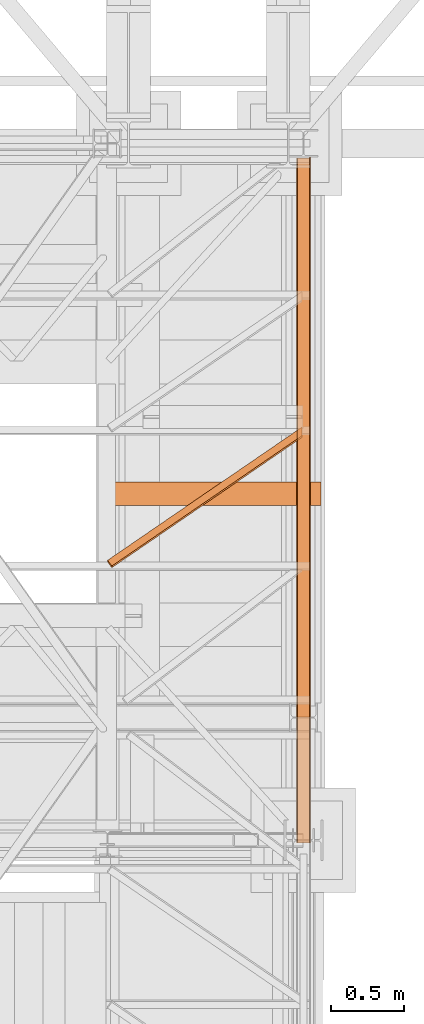
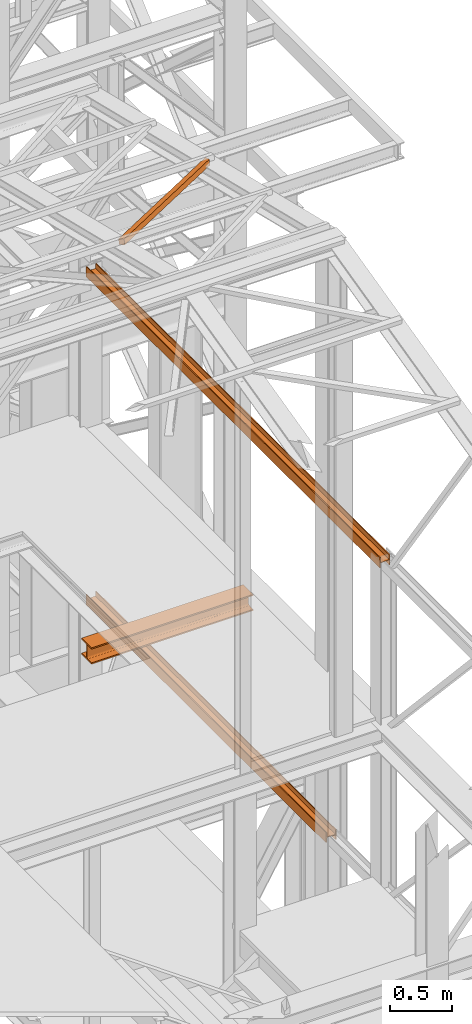
# One storey, part 66 of 208: 5 proxies.
"""IFC2X3 building model written with IfcOpenShell, lengths in millimetres."""

from ifc_helpers import new_model, entity, si_unit, converted_unit, frame, origin, origin_with_axes, place, context, subcontext, project, spatial, faceted_brep, element, save


model = new_model("IFC2X3")

# Units and contexts
model_context = context("Model", 3, precision=1e-05, world=origin())
plan_context = context("Plan", 3, precision=1e-05, world=origin())
body_context = subcontext(model_context, "Body", "Model", "MODEL_VIEW")
ifc_project = project(units=[si_unit("LENGTHUNIT", "METRE", prefix="MILLI"), converted_unit("PLANEANGLEUNIT", "DEGREE", entity("IfcPlaneAngleMeasure", 0.0174532925199433), si_unit("PLANEANGLEUNIT", "RADIAN"), dimensions=[0, 0, 0, 0, 0, 0, 0]), si_unit("AREAUNIT", "SQUARE_METRE"), si_unit("VOLUMEUNIT", "CUBIC_METRE")], contexts=[model_context, plan_context])

# Building, storey
building_placement = place(None, origin())
building = spatial("IfcBuilding", under=ifc_project, at=building_placement, CompositionType="COMPLEX")
storey_placement = place(building_placement, origin_with_axes())
storey = spatial("IfcBuildingStorey", under=building, at=storey_placement, Name="Geschoss", CompositionType="ELEMENT")

# Proxies
proxy_1_placement = place(storey_placement, frame((6650.254968528656, -22080.57439140567, 9977.24968077644), z_axis=(0.0, 0.0, 1.0), x_axis=(1.0, 0.0, 0.0)))
element("IfcBuildingElementProxy", 1, at=proxy_1_placement, inside=storey, context=body_context, shape_type="Brep", body=[
    faceted_brep([(8.010000000000218, 0.01000000000203727, 2.75031996861253), (0.01000000000021828, 0.01000000000203727, 2.75031996861253), (0.01000000000021828, 0.01000000000203727, 102.7503199686125), (8.010000000000218, 0.01000000000203727, 102.7503199686125), (8.010000000000218, 0.01000000000203727, 55.25031996861253), (88.01000000000022, 0.01000000000203727, 55.25031996861253), (88.01000000000022, 0.01000000000203727, 102.7503199686125), (96.01000000000022, 0.01000000000203727, 102.7503199686125), (96.01000000000022, 0.01000000000203727, 2.75031996861253), (88.01000000000022, 0.01000000000203727, 2.75031996861253), (88.01000000000022, 0.01000000000203727, 50.25031996861253), (8.010000000000218, 0.01000000000203727, 50.25031996861253), (0.01000000000021828, 0.01000000000203727, 2.75031996861253), (8.010000000000218, 0.01000000000203727, 2.75031996861253), (8.010000000001128, 4718.009999597674, 0.00999999999839929), (0.01000000000112777, 4718.009999597674, 0.00999999999839929), (0.01000000000021828, 0.01000000000203727, 102.7503199686125), (0.01000000000021828, 0.01000000000203727, 2.75031996861253), (0.01000000000112777, 4718.009999597674, 0.00999999999839929), (0.01000000000112777, 4718.009999597674, 100.0099999999984), (8.010000000000218, 0.01000000000203727, 102.7503199686125), (0.01000000000021828, 0.01000000000203727, 102.7503199686125), (0.01000000000112777, 4718.009999597674, 100.0099999999984), (8.010000000001128, 4718.009999597674, 100.0099999999984), (8.010000000000218, 0.01000000000203727, 55.25031996861253), (8.010000000000218, 0.01000000000203727, 102.7503199686125), (8.010000000001128, 4718.009999597674, 100.0099999999984), (8.010000000001128, 4718.009999597674, 52.5099999999984), (88.01000000000022, 0.01000000000203727, 55.25031996861253), (8.010000000000218, 0.01000000000203727, 55.25031996861253), (8.010000000001128, 4718.009999597674, 52.5099999999984), (88.01000000000113, 4718.009999597674, 52.5099999999984), (88.01000000000022, 0.01000000000203727, 102.7503199686125), (88.01000000000022, 0.01000000000203727, 55.25031996861253), (88.01000000000113, 4718.009999597674, 52.5099999999984), (88.01000000000113, 4718.009999597674, 100.0099999999984), (96.01000000000022, 0.01000000000203727, 102.7503199686125), (88.01000000000022, 0.01000000000203727, 102.7503199686125), (88.01000000000113, 4718.009999597674, 100.0099999999984), (96.01000000000113, 4718.009999597674, 100.0099999999984), (96.01000000000022, 0.01000000000203727, 2.75031996861253), (96.01000000000022, 0.01000000000203727, 102.7503199686125), (96.01000000000113, 4718.009999597674, 100.0099999999984), (96.01000000000113, 4718.009999597674, 0.00999999999839929), (88.01000000000022, 0.01000000000203727, 2.75031996861253), (96.01000000000022, 0.01000000000203727, 2.75031996861253), (96.01000000000113, 4718.009999597674, 0.00999999999839929), (88.01000000000113, 4718.009999597674, 0.00999999999839929), (88.01000000000022, 0.01000000000203727, 50.25031996861253), (88.01000000000022, 0.01000000000203727, 2.75031996861253), (88.01000000000113, 4718.009999597674, 0.00999999999839929), (88.01000000000113, 4718.009999597674, 47.5099999999984), (8.010000000000218, 0.01000000000203727, 50.25031996861253), (88.01000000000022, 0.01000000000203727, 50.25031996861253), (88.01000000000113, 4718.009999597674, 47.5099999999984), (8.010000000001128, 4718.009999597674, 47.5099999999984), (8.010000000000218, 0.01000000000203727, 2.75031996861253), (8.010000000000218, 0.01000000000203727, 50.25031996861253), (8.010000000001128, 4718.009999597674, 47.5099999999984), (8.010000000001128, 4718.009999597674, 0.00999999999839929), (8.010000000001128, 4718.009999597674, 0.00999999999839929), (8.010000000001128, 4718.009999597674, 47.5099999999984), (88.01000000000113, 4718.009999597674, 47.5099999999984), (88.01000000000113, 4718.009999597674, 0.00999999999839929), (96.01000000000113, 4718.009999597674, 0.00999999999839929), (96.01000000000113, 4718.009999597674, 100.0099999999984), (88.01000000000113, 4718.009999597674, 100.0099999999984), (88.01000000000113, 4718.009999597674, 52.5099999999984), (8.010000000001128, 4718.009999597674, 52.5099999999984), (8.010000000001128, 4718.009999597674, 100.0099999999984), (0.01000000000112777, 4718.009999597674, 100.0099999999984), (0.01000000000112777, 4718.009999597674, 0.00999999999839929)], [[[0, 1, 2, 3, 4, 5, 6, 7, 8, 9, 10, 11]], [[12, 13, 14, 15]], [[16, 17, 18, 19]], [[20, 21, 22, 23]], [[24, 25, 26, 27]], [[28, 29, 30, 31]], [[32, 33, 34, 35]], [[36, 37, 38, 39]], [[40, 41, 42, 43]], [[44, 45, 46, 47]], [[48, 49, 50, 51]], [[52, 53, 54, 55]], [[56, 57, 58, 59]], [[60, 61, 62, 63, 64, 65, 66, 67, 68, 69, 70, 71]]], orient=[[False], [False], [False], [False], [False], [False], [False], [False], [False], [False], [False], [False], [False], [False]]),
])
proxy_2_placement = place(storey_placement, frame((6650.254968528656, -22080.57439140567, 9977.24968077644), z_axis=(0.0, 0.0, 1.0), x_axis=(1.0, 0.0, 0.0)))
element("IfcBuildingElementProxy", 2, at=proxy_2_placement, inside=storey, context=body_context, shape_type="Brep", body=[
    faceted_brep([(8.010000000000218, 0.01000000000203727, 2.75031996861253), (0.01000000000021828, 0.01000000000203727, 2.75031996861253), (0.01000000000021828, 0.01000000000203727, 102.7503199686125), (8.010000000000218, 0.01000000000203727, 102.7503199686125), (8.010000000000218, 0.01000000000203727, 55.25031996861253), (88.01000000000022, 0.01000000000203727, 55.25031996861253), (88.01000000000022, 0.01000000000203727, 102.7503199686125), (96.01000000000022, 0.01000000000203727, 102.7503199686125), (96.01000000000022, 0.01000000000203727, 2.75031996861253), (88.01000000000022, 0.01000000000203727, 2.75031996861253), (88.01000000000022, 0.01000000000203727, 50.25031996861253), (8.010000000000218, 0.01000000000203727, 50.25031996861253), (0.01000000000021828, 0.01000000000203727, 2.75031996861253), (8.010000000000218, 0.01000000000203727, 2.75031996861253), (8.010000000001128, 4718.009999597674, 0.00999999999839929), (0.01000000000112777, 4718.009999597674, 0.00999999999839929), (0.01000000000021828, 0.01000000000203727, 102.7503199686125), (0.01000000000021828, 0.01000000000203727, 2.75031996861253), (0.01000000000112777, 4718.009999597674, 0.00999999999839929), (0.01000000000112777, 4718.009999597674, 100.0099999999984), (8.010000000000218, 0.01000000000203727, 102.7503199686125), (0.01000000000021828, 0.01000000000203727, 102.7503199686125), (0.01000000000112777, 4718.009999597674, 100.0099999999984), (8.010000000001128, 4718.009999597674, 100.0099999999984), (8.010000000000218, 0.01000000000203727, 55.25031996861253), (8.010000000000218, 0.01000000000203727, 102.7503199686125), (8.010000000001128, 4718.009999597674, 100.0099999999984), (8.010000000001128, 4718.009999597674, 52.5099999999984), (88.01000000000022, 0.01000000000203727, 55.25031996861253), (8.010000000000218, 0.01000000000203727, 55.25031996861253), (8.010000000001128, 4718.009999597674, 52.5099999999984), (88.01000000000113, 4718.009999597674, 52.5099999999984), (88.01000000000022, 0.01000000000203727, 102.7503199686125), (88.01000000000022, 0.01000000000203727, 55.25031996861253), (88.01000000000113, 4718.009999597674, 52.5099999999984), (88.01000000000113, 4718.009999597674, 100.0099999999984), (96.01000000000022, 0.01000000000203727, 102.7503199686125), (88.01000000000022, 0.01000000000203727, 102.7503199686125), (88.01000000000113, 4718.009999597674, 100.0099999999984), (96.01000000000113, 4718.009999597674, 100.0099999999984), (96.01000000000022, 0.01000000000203727, 2.75031996861253), (96.01000000000022, 0.01000000000203727, 102.7503199686125), (96.01000000000113, 4718.009999597674, 100.0099999999984), (96.01000000000113, 4718.009999597674, 0.00999999999839929), (88.01000000000022, 0.01000000000203727, 2.75031996861253), (96.01000000000022, 0.01000000000203727, 2.75031996861253), (96.01000000000113, 4718.009999597674, 0.00999999999839929), (88.01000000000113, 4718.009999597674, 0.00999999999839929), (88.01000000000022, 0.01000000000203727, 50.25031996861253), (88.01000000000022, 0.01000000000203727, 2.75031996861253), (88.01000000000113, 4718.009999597674, 0.00999999999839929), (88.01000000000113, 4718.009999597674, 47.5099999999984), (8.010000000000218, 0.01000000000203727, 50.25031996861253), (88.01000000000022, 0.01000000000203727, 50.25031996861253), (88.01000000000113, 4718.009999597674, 47.5099999999984), (8.010000000001128, 4718.009999597674, 47.5099999999984), (8.010000000000218, 0.01000000000203727, 2.75031996861253), (8.010000000000218, 0.01000000000203727, 50.25031996861253), (8.010000000001128, 4718.009999597674, 47.5099999999984), (8.010000000001128, 4718.009999597674, 0.00999999999839929), (8.010000000001128, 4718.009999597674, 0.00999999999839929), (8.010000000001128, 4718.009999597674, 47.5099999999984), (88.01000000000113, 4718.009999597674, 47.5099999999984), (88.01000000000113, 4718.009999597674, 0.00999999999839929), (96.01000000000113, 4718.009999597674, 0.00999999999839929), (96.01000000000113, 4718.009999597674, 100.0099999999984), (88.01000000000113, 4718.009999597674, 100.0099999999984), (88.01000000000113, 4718.009999597674, 52.5099999999984), (8.010000000001128, 4718.009999597674, 52.5099999999984), (8.010000000001128, 4718.009999597674, 100.0099999999984), (0.01000000000112777, 4718.009999597674, 100.0099999999984), (0.01000000000112777, 4718.009999597674, 0.00999999999839929)], [[[0, 1, 2, 3, 4, 5, 6, 7, 8, 9, 10, 11]], [[12, 13, 14, 15]], [[16, 17, 18, 19]], [[20, 21, 22, 23]], [[24, 25, 26, 27]], [[28, 29, 30, 31]], [[32, 33, 34, 35]], [[36, 37, 38, 39]], [[40, 41, 42, 43]], [[44, 45, 46, 47]], [[48, 49, 50, 51]], [[52, 53, 54, 55]], [[56, 57, 58, 59]], [[60, 61, 62, 63, 64, 65, 66, 67, 68, 69, 70, 71]]], orient=[[False], [False], [False], [False], [False], [False], [False], [False], [False], [False], [False], [False], [False], [False]]),
])
proxy_3_placement = place(storey_placement, frame((6650.25496814422, -21214.32439025083, 6759.989999254943), z_axis=(0.0, 0.0, 1.0), x_axis=(1.0, 0.0, 0.0)))
element("IfcBuildingElementProxy", 3, at=proxy_3_placement, inside=storey, context=body_context, shape_type="Brep", body=[
    faceted_brep([(8.010000000000218, 0.00999999999839929, 0.01000000000021828), (0.01000000000021828, 0.00999999999839929, 0.01000000000021828), (0.01000000000021828, 0.00999999999839929, 100.0100000000002), (8.010000000000218, 0.00999999999839929, 100.0100000000002), (8.010000000000218, 0.00999999999839929, 52.51000000000022), (88.01000000000022, 0.00999999999839929, 52.51000000000022), (88.01000000000022, 0.00999999999839929, 100.0100000000002), (96.00999999999931, 0.00999999999839929, 100.0100000000002), (96.00999999999931, 0.00999999999839929, 0.01000000000021828), (88.01000000000022, 0.00999999999839929, 0.01000000000021828), (88.01000000000022, 0.00999999999839929, 47.51000000000022), (8.010000000000218, 0.00999999999839929, 47.51000000000022), (0.01000000000021828, 0.00999999999839929, 0.01000000000021828), (8.010000000000218, 0.00999999999839929, 0.01000000000021828), (8.010000000000218, 3856.759984999411, 0.01000000000021828), (0.01000000000021828, 3856.759984999411, 0.01000000000021828), (0.01000000000021828, 0.00999999999839929, 100.0100000000002), (0.01000000000021828, 0.00999999999839929, 0.01000000000021828), (0.01000000000021828, 3856.759984999411, 0.01000000000021828), (0.01000000000021828, 3856.759984999411, 100.0100000000002), (8.010000000000218, 0.00999999999839929, 100.0100000000002), (0.01000000000021828, 0.00999999999839929, 100.0100000000002), (0.01000000000021828, 3856.759984999411, 100.0100000000002), (8.010000000000218, 3856.759984999411, 100.0100000000002), (8.010000000000218, 0.00999999999839929, 52.51000000000022), (8.010000000000218, 0.00999999999839929, 100.0100000000002), (8.010000000000218, 3856.759984999411, 100.0100000000002), (8.010000000000218, 3856.759984999411, 52.51000000000022), (88.01000000000022, 0.00999999999839929, 52.51000000000022), (8.010000000000218, 0.00999999999839929, 52.51000000000022), (8.010000000000218, 3856.759984999411, 52.51000000000022), (88.01000000000022, 3856.759984999411, 52.51000000000022), (88.01000000000022, 0.00999999999839929, 100.0100000000002), (88.01000000000022, 0.00999999999839929, 52.51000000000022), (88.01000000000022, 3856.759984999411, 52.51000000000022), (88.01000000000022, 3856.759984999411, 100.0100000000002), (96.00999999999931, 0.00999999999839929, 100.0100000000002), (88.01000000000022, 0.00999999999839929, 100.0100000000002), (88.01000000000022, 3856.759984999411, 100.0100000000002), (96.01000000000022, 3856.759984999411, 100.0100000000002), (96.00999999999931, 0.00999999999839929, 0.01000000000021828), (96.00999999999931, 0.00999999999839929, 100.0100000000002), (96.01000000000022, 3856.759984999411, 100.0100000000002), (96.01000000000022, 3856.759984999411, 0.01000000000021828), (88.01000000000022, 0.00999999999839929, 0.01000000000021828), (96.00999999999931, 0.00999999999839929, 0.01000000000021828), (96.01000000000022, 3856.759984999411, 0.01000000000021828), (88.01000000000022, 3856.759984999411, 0.01000000000021828), (88.01000000000022, 0.00999999999839929, 47.51000000000022), (88.01000000000022, 0.00999999999839929, 0.01000000000021828), (88.01000000000022, 3856.759984999411, 0.01000000000021828), (88.01000000000022, 3856.759984999411, 47.51000000000022), (8.010000000000218, 0.00999999999839929, 47.51000000000022), (88.01000000000022, 0.00999999999839929, 47.51000000000022), (88.01000000000022, 3856.759984999411, 47.51000000000022), (8.010000000000218, 3856.759984999411, 47.51000000000022), (8.010000000000218, 0.00999999999839929, 0.01000000000021828), (8.010000000000218, 0.00999999999839929, 47.51000000000022), (8.010000000000218, 3856.759984999411, 47.51000000000022), (8.010000000000218, 3856.759984999411, 0.01000000000021828), (8.010000000000218, 3856.759984999411, 0.01000000000021828), (8.010000000000218, 3856.759984999411, 47.51000000000022), (88.01000000000022, 3856.759984999411, 47.51000000000022), (88.01000000000022, 3856.759984999411, 0.01000000000021828), (96.01000000000022, 3856.759984999411, 0.01000000000021828), (96.01000000000022, 3856.759984999411, 100.0100000000002), (88.01000000000022, 3856.759984999411, 100.0100000000002), (88.01000000000022, 3856.759984999411, 52.51000000000022), (8.010000000000218, 3856.759984999411, 52.51000000000022), (8.010000000000218, 3856.759984999411, 100.0100000000002), (0.01000000000021828, 3856.759984999411, 100.0100000000002), (0.01000000000021828, 3856.759984999411, 0.01000000000021828)], [[[0, 1, 2, 3, 4, 5, 6, 7, 8, 9, 10, 11]], [[12, 13, 14, 15]], [[16, 17, 18, 19]], [[20, 21, 22, 23]], [[24, 25, 26, 27]], [[28, 29, 30, 31]], [[32, 33, 34, 35]], [[36, 37, 38, 39]], [[40, 41, 42, 43]], [[44, 45, 46, 47]], [[48, 49, 50, 51]], [[52, 53, 54, 55]], [[56, 57, 58, 59]], [[60, 61, 62, 63, 64, 65, 66, 67, 68, 69, 70, 71]]], orient=[[False], [False], [False], [False], [False], [False], [False], [False], [False], [False], [False], [False], [False], [False]]),
])
proxy_4_placement = place(storey_placement, frame((5349.415251226797, -20185.54963276443, 12214.24717333412), z_axis=(0.0, 0.0, 1.0), x_axis=(1.0, 0.0, 0.0)))
element("IfcBuildingElementProxy", 4, at=proxy_4_placement, inside=storey, context=body_context, shape_type="Brep", body=[
    faceted_brep([(28.82079669527684, 0.00999999999839929, 232.0521250666225), (0.009999999999308784, 39.72174452711624, 222.4128647010039), (0.009999999999308784, 51.51581022395476, 271.0019582749592), (28.82079669527684, 11.80406569683328, 280.6412186405796), (1337.349720073476, 896.5242864318316, 14.44056628674844), (28.82079669527684, 0.00999999999839929, 232.0521250666225), (28.82079669527684, 11.80406569683328, 280.6412186405796), (1337.349720073476, 908.3183521286664, 63.02965986070558), (1337.349720073476, 955.9752131652676, 0.01000000000021828), (0.009999999999308784, 39.72174452711624, 222.4128647010039), (28.82079669527684, 0.00999999999839929, 232.0521250666225), (1337.349720073476, 896.5242864318316, 14.44056628674844), (1337.349720073476, 967.7692788621025, 48.59909357395554), (0.009999999999308784, 51.51581022395476, 271.0019582749592), (0.009999999999308784, 39.72174452711624, 222.4128647010039), (1337.349720073476, 955.9752131652676, 0.01000000000021828), (1337.349720073476, 908.3183521286664, 63.02965986070558), (28.82079669527684, 11.80406569683328, 280.6412186405796), (0.009999999999308784, 51.51581022395476, 271.0019582749592), (1337.349720073476, 967.7692788621025, 48.59909357395554), (1337.349720073476, 896.5242864318316, 14.44056628674844), (1337.349720073476, 908.3183521286664, 63.02965986070558), (1337.349720073476, 967.7692788621025, 48.59909357395554), (1337.349720073476, 955.9752131652676, 0.01000000000021828)], [[[0, 1, 2, 3]], [[4, 5, 6, 7]], [[8, 9, 10, 11]], [[12, 13, 14, 15]], [[16, 17, 18, 19]], [[20, 21, 22, 23]]], orient=[[False], [False], [False], [False], [False], [False]]),
])
proxy_5_placement = place(storey_placement, frame((5318.254973297034, -19756.71764874132, 8094.989997913835), z_axis=(0.0, 0.0, 1.0), x_axis=(1.0, 0.0, 0.0)))
element("IfcBuildingElementProxy", 5, at=proxy_5_placement, inside=storey, Name="3D Element", context=body_context, shape_type="Brep", body=[
    faceted_brep([(1500.010000000003, 160.0099999999984, 0.01000000000021828), (1500.010000000003, 0.00999999999839929, 0.01000000000021828), (1500.010000000003, 0.00999999999839929, 13.01000000000022), (1500.010000000003, 61.0099999999984, 13.01000000000022), (1500.010000000003, 64.89227265598674, 13.52115656249407), (1500.010000000003, 68.50997812474452, 15.0196592323282), (1500.010000000003, 71.61660171780022, 17.40339828220203), (1500.010000000003, 74.00034076767406, 20.5100218752541), (1500.010000000003, 75.49884343750455, 24.12772734401187), (1500.010000000003, 76.0099999999984, 28.01000000000022), (1500.010000000003, 76.0099999999984, 132.0100000000002), (1500.010000000003, 75.49884343750455, 135.8922726559849), (1500.010000000003, 72.80847124273714, 141.0632899212706), (1500.010000000003, 71.61660171780022, 142.6166017177984), (1500.010000000003, 68.50997812474452, 145.0003407676722), (1500.010000000003, 64.89227265598674, 146.4988434375027), (1500.010000000003, 61.0099999999984, 147.0100000000002), (1500.010000000003, 0.00999999999839929, 147.0100000000002), (1500.010000000003, 0.00999999999839929, 160.0100000000002), (1500.010000000003, 160.0099999999984, 160.0100000000002), (1500.010000000003, 160.0099999999984, 147.0100000000002), (1500.010000000003, 99.0099999999984, 147.0100000000002), (1500.010000000003, 95.12772734401369, 146.4988434375027), (1500.010000000003, 91.51002187525592, 145.0003407676722), (1500.010000000003, 88.40339828220385, 142.6166017177984), (1500.010000000003, 86.01965923233001, 139.5099781247463), (1500.010000000003, 84.52115656249589, 135.8922726559849), (1500.010000000003, 84.0099999999984, 132.0100000000002), (1500.010000000003, 84.0099999999984, 28.01000000000022), (1500.010000000003, 84.74420336541152, 23.37476080785382), (1500.010000000003, 86.87476363144378, 19.19323607455408), (1500.010000000003, 90.1932360745559, 15.87476363144197), (1500.010000000003, 94.37476080785564, 13.7442033654097), (1500.010000000003, 99.0099999999984, 13.01000000000022), (1500.010000000003, 160.0099999999984, 13.01000000000022), (1500.010000000003, 0.00999999999839929, 0.01000000000021828), (1500.010000000003, 160.0099999999984, 0.01000000000021828), (0.01000000000021828, 160.0100000000057, 0.01000000000021828), (0.01000000000021828, 0.01000000000567525, 0.01000000000021828), (1500.010000000003, 0.00999999999839929, 13.01000000000022), (1500.010000000003, 0.00999999999839929, 0.01000000000021828), (0.01000000000021828, 0.01000000000567525, 0.01000000000021828), (0.01000000000021828, 0.01000000000567525, 13.01000000000022), (1500.010000000003, 61.0099999999984, 13.01000000000022), (1500.010000000003, 0.00999999999839929, 13.01000000000022), (0.01000000000021828, 0.01000000000567525, 13.01000000000022), (0.01000000000021828, 61.01000000000568, 13.01000000000022), (1500.010000000003, 64.89227265598674, 13.52115656249407), (1500.010000000003, 61.0099999999984, 13.01000000000022), (0.01000000000021828, 61.01000000000568, 13.01000000000022), (0.01000000000021828, 64.89227265599402, 13.52115656249407), (1500.010000000003, 68.50997812474452, 15.0196592323282), (1500.010000000003, 64.89227265598674, 13.52115656249407), (0.01000000000021828, 64.89227265599402, 13.52115656249407), (0.01000000000021828, 68.5099781247518, 15.0196592323282), (1500.010000000003, 71.61660171780022, 17.40339828220203), (1500.010000000003, 68.50997812474452, 15.0196592323282), (0.01000000000021828, 68.5099781247518, 15.0196592323282), (0.01000000000021828, 71.6166017178075, 17.40339828220203), (1500.010000000003, 74.00034076767406, 20.5100218752541), (1500.010000000003, 71.61660171780022, 17.40339828220203), (0.01000000000021828, 71.6166017178075, 17.40339828220203), (0.01000000000021828, 74.00034076768134, 20.5100218752541), (1500.010000000003, 75.49884343750455, 24.12772734401187), (1500.010000000003, 74.00034076767406, 20.5100218752541), (0.01000000000021828, 74.00034076768134, 20.5100218752541), (0.01000000000021828, 75.49884343751182, 24.12772734401187), (1500.010000000003, 76.0099999999984, 28.01000000000022), (1500.010000000003, 75.49884343750455, 24.12772734401187), (0.01000000000021828, 75.49884343751182, 24.12772734401187), (0.01000000000021828, 76.01000000000568, 28.01000000000022), (1500.010000000003, 76.0099999999984, 132.0100000000002), (1500.010000000003, 76.0099999999984, 28.01000000000022), (0.01000000000021828, 76.01000000000568, 28.01000000000022), (0.01000000000021828, 76.01000000000568, 132.0100000000002), (1500.010000000003, 75.49884343750455, 135.8922726559849), (1500.010000000003, 76.0099999999984, 132.0100000000002), (0.01000000000021828, 76.01000000000568, 132.0100000000002), (0.01000000000021828, 75.49884343751182, 135.8922726559849), (1500.010000000003, 72.80847124273714, 141.0632899212706), (1500.010000000003, 75.49884343750455, 135.8922726559849), (0.01000000000021828, 75.49884343751182, 135.8922726559849), (0.01000000000021828, 72.80847124274442, 141.0632899212706), (1500.010000000003, 71.61660171780022, 142.6166017177984), (1500.010000000003, 72.80847124273714, 141.0632899212706), (0.01000000000021828, 72.80847124274442, 141.0632899212706), (0.01000000000021828, 71.6166017178075, 142.6166017177984), (1500.010000000003, 68.50997812474452, 145.0003407676722), (1500.010000000003, 71.61660171780022, 142.6166017177984), (0.01000000000021828, 71.6166017178075, 142.6166017177984), (0.01000000000021828, 68.5099781247518, 145.0003407676722), (1500.010000000003, 64.89227265598674, 146.4988434375027), (1500.010000000003, 68.50997812474452, 145.0003407676722), (0.01000000000021828, 68.5099781247518, 145.0003407676722), (0.01000000000021828, 64.89227265599402, 146.4988434375027), (1500.010000000003, 61.0099999999984, 147.0100000000002), (1500.010000000003, 64.89227265598674, 146.4988434375027), (0.01000000000021828, 64.89227265599402, 146.4988434375027), (0.01000000000021828, 61.01000000000568, 147.0100000000002), (1500.010000000003, 0.00999999999839929, 147.0100000000002), (1500.010000000003, 61.0099999999984, 147.0100000000002), (0.01000000000021828, 61.01000000000568, 147.0100000000002), (0.01000000000021828, 0.01000000000567525, 147.0100000000002), (1500.010000000003, 0.00999999999839929, 160.0100000000002), (1500.010000000003, 0.00999999999839929, 147.0100000000002), (0.01000000000021828, 0.01000000000567525, 147.0100000000002), (0.01000000000021828, 0.01000000000567525, 160.0100000000002), (1500.010000000003, 160.0099999999984, 160.0100000000002), (1500.010000000003, 0.00999999999839929, 160.0100000000002), (0.01000000000021828, 0.01000000000567525, 160.0100000000002), (0.01000000000021828, 160.0100000000057, 160.0100000000002), (1500.010000000003, 160.0099999999984, 147.0100000000002), (1500.010000000003, 160.0099999999984, 160.0100000000002), (0.01000000000021828, 160.0100000000057, 160.0100000000002), (0.01000000000021828, 160.0100000000057, 147.0100000000002), (1500.010000000003, 99.0099999999984, 147.0100000000002), (1500.010000000003, 160.0099999999984, 147.0100000000002), (0.01000000000021828, 160.0100000000057, 147.0100000000002), (0.01000000000021828, 99.01000000000568, 147.0100000000002), (1500.010000000003, 95.12772734401369, 146.4988434375027), (1500.010000000003, 99.0099999999984, 147.0100000000002), (0.01000000000021828, 99.01000000000568, 147.0100000000002), (0.01000000000021828, 95.12772734402097, 146.4988434375027), (1500.010000000003, 91.51002187525592, 145.0003407676722), (1500.010000000003, 95.12772734401369, 146.4988434375027), (0.01000000000021828, 95.12772734402097, 146.4988434375027), (0.01000000000021828, 91.51002187526319, 145.0003407676722), (1500.010000000003, 88.40339828220385, 142.6166017177984), (1500.010000000003, 91.51002187525592, 145.0003407676722), (0.01000000000021828, 91.51002187526319, 145.0003407676722), (0.01000000000021828, 88.40339828221113, 142.6166017177984), (1500.010000000003, 86.01965923233001, 139.5099781247463), (1500.010000000003, 88.40339828220385, 142.6166017177984), (0.01000000000021828, 88.40339828221113, 142.6166017177984), (0.01000000000021828, 86.01965923233729, 139.5099781247463), (1500.010000000003, 84.52115656249589, 135.8922726559849), (1500.010000000003, 86.01965923233001, 139.5099781247463), (0.01000000000021828, 86.01965923233729, 139.5099781247463), (0.01000000000021828, 84.52115656250317, 135.8922726559849), (1500.010000000003, 84.0099999999984, 132.0100000000002), (1500.010000000003, 84.52115656249589, 135.8922726559849), (0.01000000000021828, 84.52115656250317, 135.8922726559849), (0.01000000000021828, 84.01000000000568, 132.0100000000002), (1500.010000000003, 84.0099999999984, 28.01000000000022), (1500.010000000003, 84.0099999999984, 132.0100000000002), (0.01000000000021828, 84.01000000000568, 132.0100000000002), (0.01000000000021828, 84.01000000000568, 28.01000000000022), (1500.010000000003, 84.74420336541152, 23.37476080785382), (1500.010000000003, 84.0099999999984, 28.01000000000022), (0.01000000000021828, 84.01000000000568, 28.01000000000022), (0.01000000000021828, 84.7442033654188, 23.37476080785382), (1500.010000000003, 86.87476363144378, 19.19323607455408), (1500.010000000003, 84.74420336541152, 23.37476080785382), (0.01000000000021828, 84.7442033654188, 23.37476080785382), (0.01000000000021828, 86.87476363145106, 19.19323607455408), (1500.010000000003, 90.1932360745559, 15.87476363144197), (1500.010000000003, 86.87476363144378, 19.19323607455408), (0.01000000000021828, 86.87476363145106, 19.19323607455408), (0.01000000000021828, 90.19323607456317, 15.87476363144197), (1500.010000000003, 94.37476080785564, 13.7442033654097), (1500.010000000003, 90.1932360745559, 15.87476363144197), (0.01000000000021828, 90.19323607456317, 15.87476363144197), (0.01000000000021828, 94.37476080786291, 13.7442033654097), (1500.010000000003, 99.0099999999984, 13.01000000000022), (1500.010000000003, 94.37476080785564, 13.7442033654097), (0.01000000000021828, 94.37476080786291, 13.7442033654097), (0.01000000000021828, 99.01000000000568, 13.01000000000022), (1500.010000000003, 160.0099999999984, 13.01000000000022), (1500.010000000003, 99.0099999999984, 13.01000000000022), (0.01000000000021828, 99.01000000000568, 13.01000000000022), (0.01000000000021828, 160.0100000000057, 13.01000000000022), (1500.010000000003, 160.0099999999984, 0.01000000000021828), (1500.010000000003, 160.0099999999984, 13.01000000000022), (0.01000000000021828, 160.0100000000057, 13.01000000000022), (0.01000000000021828, 160.0100000000057, 0.01000000000021828), (0.01000000000021828, 160.0100000000057, 0.01000000000021828), (0.01000000000021828, 160.0100000000057, 13.01000000000022), (0.01000000000021828, 99.01000000000568, 13.01000000000022), (0.01000000000021828, 94.37476080786291, 13.7442033654097), (0.01000000000021828, 90.19323607456317, 15.87476363144197), (0.01000000000021828, 86.87476363145106, 19.19323607455408), (0.01000000000021828, 84.7442033654188, 23.37476080785382), (0.01000000000021828, 84.01000000000568, 28.01000000000022), (0.01000000000021828, 84.01000000000568, 132.0100000000002), (0.01000000000021828, 84.52115656250317, 135.8922726559849), (0.01000000000021828, 86.01965923233729, 139.5099781247463), (0.01000000000021828, 88.40339828221113, 142.6166017177984), (0.01000000000021828, 91.51002187526319, 145.0003407676722), (0.01000000000021828, 95.12772734402097, 146.4988434375027), (0.01000000000021828, 99.01000000000568, 147.0100000000002), (0.01000000000021828, 160.0100000000057, 147.0100000000002), (0.01000000000021828, 160.0100000000057, 160.0100000000002), (0.01000000000021828, 0.01000000000567525, 160.0100000000002), (0.01000000000021828, 0.01000000000567525, 147.0100000000002), (0.01000000000021828, 61.01000000000568, 147.0100000000002), (0.01000000000021828, 64.89227265599402, 146.4988434375027), (0.01000000000021828, 68.5099781247518, 145.0003407676722), (0.01000000000021828, 71.6166017178075, 142.6166017177984), (0.01000000000021828, 72.80847124274442, 141.0632899212706), (0.01000000000021828, 75.49884343751182, 135.8922726559849), (0.01000000000021828, 76.01000000000568, 132.0100000000002), (0.01000000000021828, 76.01000000000568, 28.01000000000022), (0.01000000000021828, 75.49884343751182, 24.12772734401187), (0.01000000000021828, 74.00034076768134, 20.5100218752541), (0.01000000000021828, 71.6166017178075, 17.40339828220203), (0.01000000000021828, 68.5099781247518, 15.0196592323282), (0.01000000000021828, 64.89227265599402, 13.52115656249407), (0.01000000000021828, 61.01000000000568, 13.01000000000022), (0.01000000000021828, 0.01000000000567525, 13.01000000000022), (0.01000000000021828, 0.01000000000567525, 0.01000000000021828)], [[[0, 1, 2, 3, 4, 5, 6, 7, 8, 9, 10, 11, 12, 13, 14, 15, 16, 17, 18, 19, 20, 21, 22, 23, 24, 25, 26, 27, 28, 29, 30, 31, 32, 33, 34]], [[35, 36, 37, 38]], [[39, 40, 41, 42]], [[43, 44, 45, 46]], [[47, 48, 49, 50]], [[51, 52, 53, 54]], [[55, 56, 57, 58]], [[59, 60, 61, 62]], [[63, 64, 65, 66]], [[67, 68, 69, 70]], [[71, 72, 73, 74]], [[75, 76, 77, 78]], [[79, 80, 81, 82]], [[83, 84, 85, 86]], [[87, 88, 89, 90]], [[91, 92, 93, 94]], [[95, 96, 97, 98]], [[99, 100, 101, 102]], [[103, 104, 105, 106]], [[107, 108, 109, 110]], [[111, 112, 113, 114]], [[115, 116, 117, 118]], [[119, 120, 121, 122]], [[123, 124, 125, 126]], [[127, 128, 129, 130]], [[131, 132, 133, 134]], [[135, 136, 137, 138]], [[139, 140, 141, 142]], [[143, 144, 145, 146]], [[147, 148, 149, 150]], [[151, 152, 153, 154]], [[155, 156, 157, 158]], [[159, 160, 161, 162]], [[163, 164, 165, 166]], [[167, 168, 169, 170]], [[171, 172, 173, 174]], [[175, 176, 177, 178, 179, 180, 181, 182, 183, 184, 185, 186, 187, 188, 189, 190, 191, 192, 193, 194, 195, 196, 197, 198, 199, 200, 201, 202, 203, 204, 205, 206, 207, 208, 209]]], orient=[[False], [False], [False], [False], [False], [False], [False], [False], [False], [False], [False], [False], [False], [False], [False], [False], [False], [False], [False], [False], [False], [False], [False], [False], [False], [False], [False], [False], [False], [False], [False], [False], [False], [False], [False], [False], [False]]),
])

save(model, "model.ifc")
